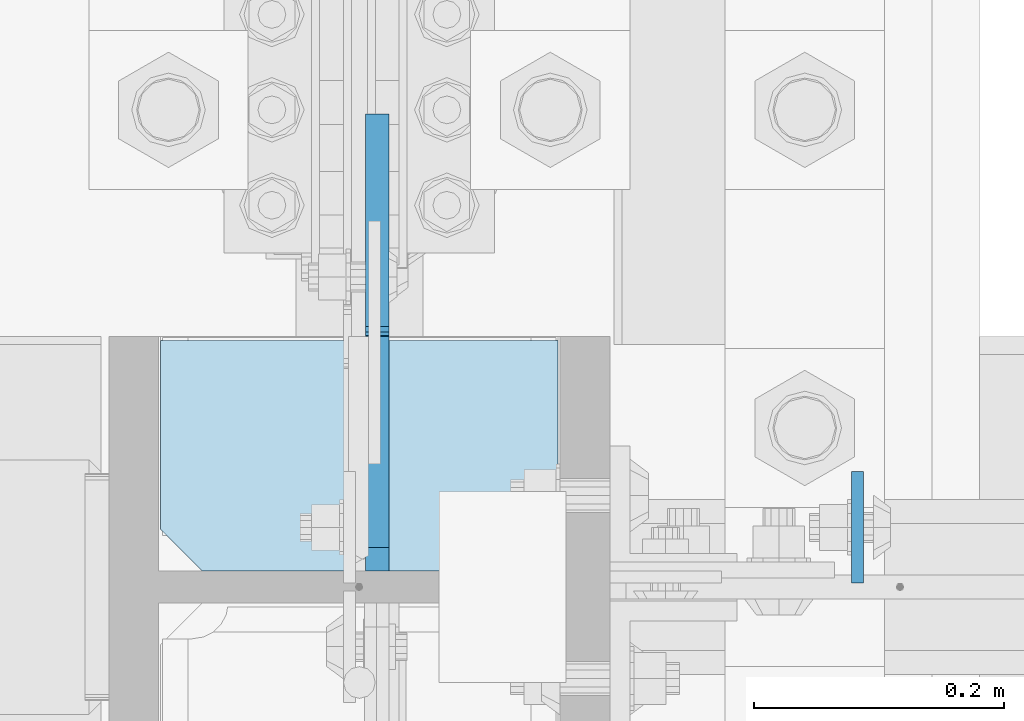
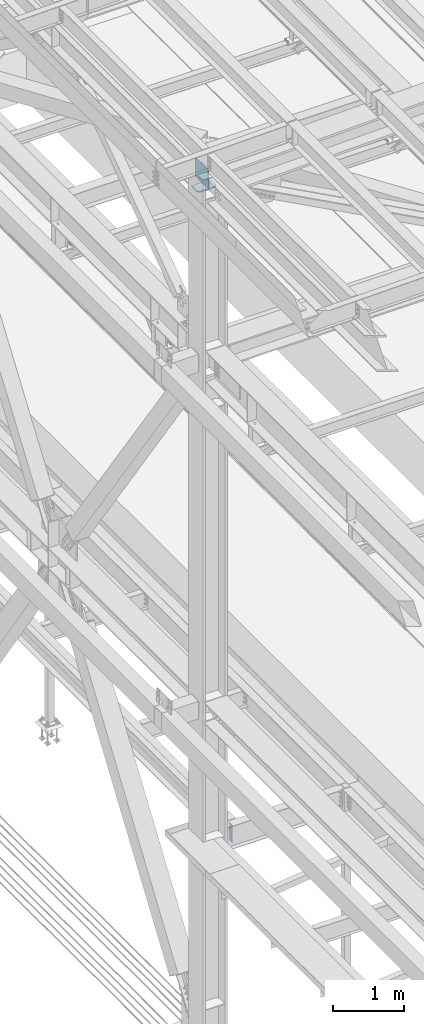
# One storey, part 3342 of 3843: 3 plates, 2 elements without a shape of their own.
"""IFC2X3 building model written with IfcOpenShell, lengths in millimetres."""

from ifc_helpers import new_model, si_unit, frame, origin_with_axes, place, context, subcontext, project, spatial, faceted_brep, material, type_object, element, aggregate, save


model = new_model("IFC2X3")

# Units and contexts
model_context = context("Model", 3, precision=1e-05, world=origin_with_axes())
body_context = subcontext(model_context, "Body", "Model", "MODEL_VIEW")
ifc_project = project(units=[si_unit("LENGTHUNIT", "METRE", prefix="MILLI"), si_unit("AREAUNIT", "SQUARE_METRE"), si_unit("VOLUMEUNIT", "CUBIC_METRE"), si_unit("MASSUNIT", "GRAM", prefix="KILO"), si_unit("TIMEUNIT", "SECOND"), si_unit("PLANEANGLEUNIT", "RADIAN"), si_unit("SOLIDANGLEUNIT", "STERADIAN"), si_unit("THERMODYNAMICTEMPERATUREUNIT", "DEGREE_CELSIUS"), si_unit("LUMINOUSINTENSITYUNIT", "LUMEN")], contexts=[model_context])

# Site, building, storey
site_placement = place(None, origin_with_axes())
site = spatial("IfcSite", under=ifc_project, at=site_placement, CompositionType="ELEMENT")
building_placement = place(site_placement, origin_with_axes())
building = spatial("IfcBuilding", under=site, at=building_placement, Name="Undefined", CompositionType="ELEMENT")
storey_placement = place(building_placement, origin_with_axes())
storey = spatial("IfcBuildingStorey", under=building, at=storey_placement, Name="Undefined", CompositionType="ELEMENT", Elevation=0.0)

# Assembly, plate
assembly_1_placement = place(storey_placement, origin_with_axes())
assembly_1 = element("IfcElementAssembly", 1, at=assembly_1_placement, inside=storey, Name="BEAM", AssemblyPlace="NOTDEFINED", PredefinedType="RIGID_FRAME")
ifc_material = material(Name="STEEL/A572-50")
plate_type_1 = type_object("IfcPlateType", PredefinedType="NOTDEFINED")
plate_1_placement = place(assembly_1_placement, frame((36973.66875, 67275.075, 33997.9), z_axis=(0.0, 1.0, 0.0), x_axis=(0.0, 0.0, -1.0)))
plate_1 = element("IfcPlate", 2, at=plate_1_placement, type_object=plate_type_1, material=ifc_material, Name="PLATE", context=body_context, shape_type="Brep", body=[
    faceted_brep([(0.0, -4.76249999999709, 0.0), (0.0, -4.76249999999709, 88.9000015258789), (0.0, 4.76249999999709, 88.9000015258789), (0.0, 4.76249999999709, 0.0), (304.800000000003, -4.76249999999709, 88.8999999999942), (304.800000000003, 4.76249999999709, 88.8999999999942), (304.800000000003, -4.76249999999709, 0.0), (304.800000000003, 4.76249999999709, 0.0)], [[[0, 1, 2, 3]], [[1, 4, 5, 2]], [[4, 6, 7, 5]], [[6, 0, 3, 7]], [[5, 7, 3, 2]], [[6, 4, 1, 0]]]),
])
aggregate(assembly_1, [plate_1])

# Assembly, plates
assembly_2_placement = place(storey_placement, origin_with_axes())
assembly_2 = element("IfcElementAssembly", 3, at=assembly_2_placement, inside=storey, Name="COLUMN", AssemblyPlace="NOTDEFINED", PredefinedType="RIGID_FRAME")
plate_type_2 = type_object("IfcPlateType", PredefinedType="NOTDEFINED")
plate_2_placement = place(assembly_2_placement, frame((36734.75, 67468.75, 45059.5999999997), z_axis=(-1.0, 0.0, 0.0), x_axis=(0.0, -1.0, 0.0)))
plate_2 = element("IfcPlate", 4, at=plate_2_placement, type_object=plate_type_2, material=ifc_material, Name="PLATE", context=body_context, shape_type="Brep", body=[
    faceted_brep([(0.0, -9.52500000000146, 0.0), (0.0, -9.52500000000146, 317.5), (0.0, 9.52500000000146, 317.5), (0.0, 9.52500000000146, 0.0), (150.81249847413, -9.52500000000146, 317.5), (150.81249847413, 9.52500000000146, 317.5), (184.150000000009, -9.52500000000146, 284.162498474121), (184.150000000009, 9.52500000000146, 284.162498474121), (184.150000000009, -9.52500000000146, 33.3375015258789), (184.150000000009, 9.52500000000146, 33.3375015258789), (150.81249847413, -9.52500000000146, 0.0), (150.81249847413, 9.52500000000146, 0.0)], [[[0, 1, 2, 3]], [[1, 4, 5, 2]], [[4, 6, 7, 5]], [[6, 8, 9, 7]], [[8, 10, 11, 9]], [[10, 0, 3, 11]], [[5, 7, 9, 11, 3, 2]], [[10, 8, 6, 4, 1, 0]]]),
])
plate_type_3 = type_object("IfcPlateType", PredefinedType="NOTDEFINED")
plate_3_placement = place(assembly_2_placement, frame((36590.2875004394, 67284.6, 45088.175002792), z_axis=(0.0, 0.707106781186548, 0.707106781186548), x_axis=(5.70000238222118e-08, 0.707106781186546, -0.707106781186546)))
plate_3 = element("IfcPlate", 5, at=plate_3_placement, type_object=plate_type_3, material=ifc_material, Name="PLATE", context=body_context, shape_type="Brep", body=[
    faceted_brep([(0.0, -9.52500000000146, 0.0), (-206.545892322774, -9.52500000000146, 206.545889244429), (-206.545892322774, 9.52500000000146, 206.545889244429), (0.0, 9.52500000000146, 0.0), (-206.545892322807, -9.52500000000146, 233.486657406793), (-206.545892322807, 9.52500000000146, 233.486657406793), (-87.5574981562204, -9.52500000000146, 352.475049513436), (-87.5574981562204, 9.52500000000146, 352.475049513436), (-83.4373216675631, -9.52500000000146, 349.722035643659), (-83.4373216675631, 9.52500000000146, 349.722035643659), (-78.5772421423244, -9.52500000000146, 348.755305757295), (-78.5772421423244, 9.52500000000146, 348.755305757295), (-73.7171626314957, -9.52500000000146, 349.722035716099), (-73.7171626314957, 9.52500000000146, 349.722035716099), (-69.5969861838676, -9.52500000000146, 352.47504964727), (-69.5969861838676, 9.52500000000146, 352.47504964727), (47.1463462352222, -9.52500000000146, 469.218383806307), (47.1463462352222, 9.52500000000146, 469.218383806307), (271.652750933881, -9.52500000000146, 244.711982453664), (271.652750933881, 9.52500000000146, 244.711982453664), (26.9407683632344, -9.52499999999964, 2.03726813197136e-10), (26.9407683632344, 9.52499999999964, 2.03726813197136e-10)], [[[0, 1, 2, 3]], [[1, 4, 5, 2]], [[4, 6, 7, 5]], [[6, 8, 9, 7]], [[8, 10, 11, 9]], [[10, 12, 13, 11]], [[12, 14, 15, 13]], [[14, 16, 17, 15]], [[16, 18, 19, 17]], [[18, 20, 21, 19]], [[20, 0, 3, 21]], [[5, 7, 9, 11, 13, 15, 17, 19, 21, 3, 2]], [[20, 18, 16, 14, 12, 10, 8, 6, 4, 1, 0]]]),
])
aggregate(assembly_2, [plate_2, plate_3])

save(model, "model.ifc")
